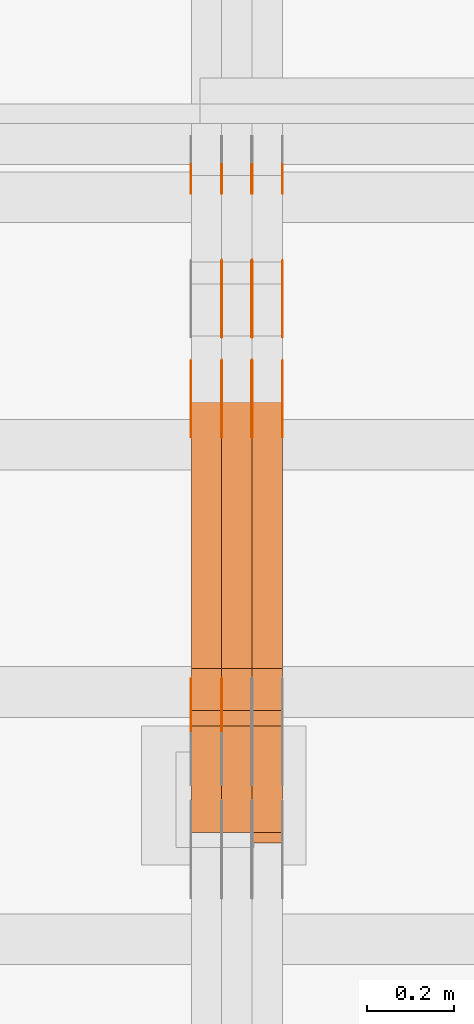
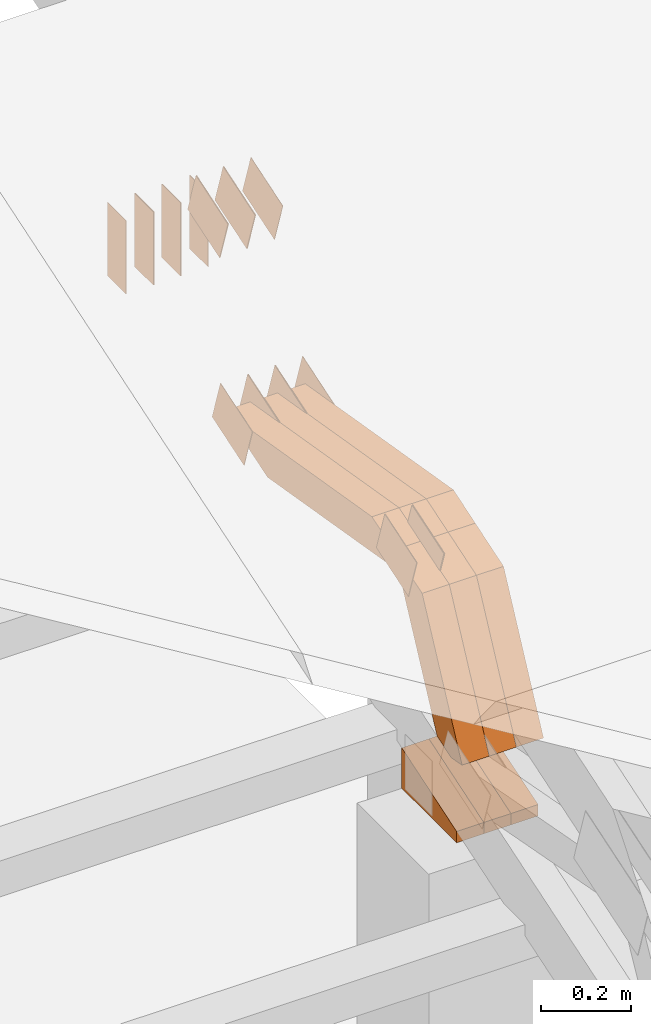
# One storey, part 298 of 385: 29 proxies.
"""IFC2X3 building model written with IfcOpenShell, lengths in millimetres."""

import ifcopenshell
import ifcopenshell.guid

model = None  # the IFC model being written
_history = None  # IfcOwnerHistory: only IFC2X3 demands one
_inside = {}  # id of a spatial element -> (the spatial element, [elements in it])
_under = {}  # id of a project, library or spatial element -> (it, [spatial elements below it])
_declared = {}  # id of a project -> (the project, [libraries it declares])
_typed = {}  # id of a type object -> (the type object, [elements of that type])
_made_of = {}  # id of a material, layer set ... -> (it, [elements and type objects made of it])


def new_model(schema):
    """Start an empty IFC model of exactly this schema.

    Asked for "IFC4X3", IfcOpenShell would pick the latest addendum, in which some entities
    have other attributes; the version numbers below select the first issue.
    IFC2X3 requires an IfcOwnerHistory on every rooted entity: one is made here for all.
    """
    global model, _history
    if schema == "IFC4X3":
        model = ifcopenshell.file(schema_version=(4, 3, 0, 0))
    else:
        model = ifcopenshell.file(schema=schema)
    _inside.clear()
    _under.clear()
    _declared.clear()
    _typed.clear()
    _made_of.clear()
    _history = None
    if model.schema == "IFC2X3":
        org = make("IfcOrganization", Name="unknown")
        user = make(
            "IfcPersonAndOrganization",
            ThePerson=make("IfcPerson", FamilyName="unknown"),
            TheOrganization=org,
        )
        app = make(
            "IfcApplication",
            ApplicationDeveloper=org,
            Version="unknown",
            ApplicationFullName="unknown",
            ApplicationIdentifier="unknown",
        )
        _history = make(
            "IfcOwnerHistory",
            OwningUser=user,
            OwningApplication=app,
            ChangeAction="ADDED",
            CreationDate=0,
        )
    return model


def make(cls, **values):
    """One entity of the class cls with the attributes given. An attribute that is None is left unset."""
    return model.create_entity(
        cls, **{name: value for name, value in values.items() if value is not None}
    )


def entity(cls, *values):
    """Any entity or typed value of the class cls, its attributes in the order of the schema. None: left unset."""
    e = model.create_entity(cls)
    for i, value in enumerate(values):
        if value is not None:
            e[i] = value
    return e


def rooted(cls, **values):
    """An entity with a GlobalId (a new one), such as an element, a storey or a relation."""
    return make(cls, GlobalId=ifcopenshell.guid.new(), OwnerHistory=_history, **values)


def si_unit(unit_type, name, prefix=None):
    """IfcSIUnit, for example si_unit("LENGTHUNIT", "METRE", prefix="MILLI")."""
    return make("IfcSIUnit", UnitType=unit_type, Prefix=prefix, Name=name)


def converted_unit(unit_type, name, factor, base, dimensions=None, offset=None):
    """IfcConversionBasedUnit, such as the inch: factor (a typed value) times the base unit."""
    return make(
        "IfcConversionBasedUnit"
        if offset is None
        else "IfcConversionBasedUnitWithOffset",
        ConversionOffset=offset,
        Dimensions=None
        if dimensions is None
        else entity("IfcDimensionalExponents", *dimensions),
        UnitType=unit_type,
        Name=name,
        ConversionFactor=make(
            "IfcMeasureWithUnit", ValueComponent=factor, UnitComponent=base
        ),
    )


def derived_unit(unit_type, elements):
    """IfcDerivedUnit: a product of units, each with its exponent."""
    return make(
        "IfcDerivedUnit",
        Elements=[
            make("IfcDerivedUnitElement", Unit=unit, Exponent=power)
            for unit, power in elements
        ],
        UnitType=unit_type,
    )


def assignment(units):
    """IfcUnitAssignment: the units of a project."""
    return None if units is None else make("IfcUnitAssignment", Units=units)


def point(xyz):
    """IfcCartesianPoint."""
    return None if xyz is None else make("IfcCartesianPoint", Coordinates=xyz)


def direction(xyz):
    """IfcDirection."""
    return None if xyz is None else make("IfcDirection", DirectionRatios=xyz)


def frame(location, z_axis=None, x_axis=None):
    """IfcAxis2Placement3D, a coordinate frame: its origin and axes. An axis left out is left unset."""
    return make(
        "IfcAxis2Placement3D",
        Location=point(location),
        Axis=direction(z_axis),
        RefDirection=direction(x_axis),
    )


def frame_2d(location, x_axis=None):
    """IfcAxis2Placement2D, a coordinate frame in the plane: its origin and x axis."""
    return make(
        "IfcAxis2Placement2D", Location=point(location), RefDirection=direction(x_axis)
    )


def origin():
    """The frame at (0, 0, 0) with its axes left unset."""
    return frame((0.0, 0.0, 0.0))


def place(relative_to, where):
    """IfcLocalPlacement: puts the frame where relative to a parent placement (None: the world)."""
    return make(
        "IfcLocalPlacement", PlacementRelTo=relative_to, RelativePlacement=where
    )


def context(
    kind, dimensions, precision=None, world=None, true_north=None, identifier=None
):
    """IfcGeometricRepresentationContext, for example the 3D "Model" context."""
    return make(
        "IfcGeometricRepresentationContext",
        ContextIdentifier=identifier,
        ContextType=kind,
        CoordinateSpaceDimension=dimensions,
        Precision=precision,
        WorldCoordinateSystem=world,
        TrueNorth=true_north,
    )


def subcontext(parent, identifier, kind, view, scale=None):
    """IfcGeometricRepresentationSubContext, for example "Body" below "Model"."""
    return make(
        "IfcGeometricRepresentationSubContext",
        ContextIdentifier=identifier,
        ContextType=kind,
        ParentContext=parent,
        TargetScale=scale,
        TargetView=view,
    )


def project(units=None, contexts=None):
    """IfcProject with its units and contexts."""
    return rooted(
        "IfcProject",
        Name="project",
        RepresentationContexts=contexts,
        UnitsInContext=assignment(units),
    )


def spatial(cls, under=None, at=None, **own):
    """A site, building, storey or space (cls), placed at a placement, below another one or the project."""
    s = rooted(cls, ObjectPlacement=at, **own)
    if under is not None:
        _under.setdefault(under.id(), (under, []))[1].append(s)
    return s


def polyline(points):
    """IfcPolyline through the points."""
    return make("IfcPolyline", Points=[point(p) for p in points])


def profile(cls, at=None, kind="AREA", **sizes):
    """A parametric profile (cls). Its sizes go by their IFC names, for example OverallWidth=200.0."""
    return make(cls, ProfileType=kind, Position=at, **sizes)


def rectangle(**sizes):
    """IfcRectangleProfileDef."""
    return profile("IfcRectangleProfileDef", **sizes)


def outline(outer, holes=None, kind="AREA"):
    """IfcArbitraryClosedProfileDef: a profile drawn as a closed curve; with holes, ...WithVoids."""
    if holes is None:
        return make("IfcArbitraryClosedProfileDef", ProfileType=kind, OuterCurve=outer)
    return make(
        "IfcArbitraryProfileDefWithVoids",
        ProfileType=kind,
        OuterCurve=outer,
        InnerCurves=holes,
    )


def extrude(swept, where, along, depth):
    """IfcExtrudedAreaSolid: the profile swept, set in the frame where, extruded along a direction by depth."""
    return make(
        "IfcExtrudedAreaSolid",
        SweptArea=swept,
        Position=where,
        ExtrudedDirection=direction(along),
        Depth=depth,
    )


def shape(context_of_items, identifier, shape_type, items):
    """IfcShapeRepresentation: the items that make up one representation, for example the "Body"."""
    return make(
        "IfcShapeRepresentation",
        ContextOfItems=context_of_items,
        RepresentationIdentifier=identifier,
        RepresentationType=shape_type,
        Items=items,
    )


def source(mapping_origin, context_of_items, identifier, shape_type, items):
    """IfcRepresentationMap: a shape defined once, which mapped items show again and again."""
    return make(
        "IfcRepresentationMap",
        MappingOrigin=mapping_origin,
        MappedRepresentation=shape(context_of_items, identifier, shape_type, items),
    )


def transform(
    local_origin,
    x_axis=None,
    y_axis=None,
    z_axis=None,
    scale=None,
    scale2=None,
    scale3=None,
    uniform=True,
):
    """IfcCartesianTransformationOperator3D, or its non-uniform kind. x_axis, y_axis, z_axis: its Axis1, 2, 3."""
    if uniform:
        return make(
            "IfcCartesianTransformationOperator3D",
            Axis1=direction(x_axis),
            Axis2=direction(y_axis),
            LocalOrigin=point(local_origin),
            Scale=scale,
            Axis3=direction(z_axis),
        )
    return make(
        "IfcCartesianTransformationOperator3DnonUniform",
        Axis1=direction(x_axis),
        Axis2=direction(y_axis),
        LocalOrigin=point(local_origin),
        Scale=scale,
        Axis3=direction(z_axis),
        Scale2=scale2,
        Scale3=scale3,
    )


def mapped(mapping_source, mapping_target):
    """IfcMappedItem: shows the shape of a source again, moved by a transform."""
    return make(
        "IfcMappedItem", MappingSource=mapping_source, MappingTarget=mapping_target
    )


def material(Name=None, Category=None):
    """IfcMaterial."""
    return make("IfcMaterial", Name=Name, Category=Category)


def made_of(thing, what):
    """Note that an element or type object is made of a material, layer set ...; save() writes the relation."""
    if what is not None:
        _made_of.setdefault(what.id(), (what, []))[1].append(thing)
    return thing


def type_object(cls, material=None, **own):
    """A type object (cls), such as IfcWallType, which elements share."""
    return made_of(rooted(cls, **own), material)


def type_shapes(of_type, sources):
    """Give a type object the sources (RepresentationMaps) that its elements show as mapped items."""
    of_type.RepresentationMaps = sources


def element(
    cls,
    number,
    at=None,
    inside=None,
    cuts=None,
    type_object=None,
    material=None,
    context=None,
    identifier="Body",
    shape_type=None,
    held_by="IfcProductDefinitionShape",
    body=None,
    shapes=None,
    **own,
):
    """One element of the class cls, such as IfcWall. Its Tag is "e" and its number.

    at: its placement. inside: the storey or other place that contains it. cuts: it is an
    opening in that element (IfcRelVoidsElement). A single representation is given by context,
    identifier, shape_type and body (its items); several are given by shapes. held_by: the class
    of the entity that holds the representations. save() writes the other relations.
    """
    e = rooted(cls, Tag="e%d" % number, ObjectPlacement=at, **own)
    if body is not None:
        shapes = [shape(context, identifier, shape_type, body)]
    if shapes is not None:
        e.Representation = make(held_by, Representations=shapes)
    if inside is not None:
        _inside.setdefault(inside.id(), (inside, []))[1].append(e)
    if cuts is not None:
        rooted(
            "IfcRelVoidsElement", RelatingBuildingElement=cuts, RelatedOpeningElement=e
        )
    if type_object is not None:
        _typed.setdefault(type_object.id(), (type_object, []))[1].append(e)
    return made_of(e, material)


def aggregate(whole, parts):
    """IfcRelAggregates: a whole, such as a stair, and the parts it consists of."""
    return rooted("IfcRelAggregates", RelatingObject=whole, RelatedObjects=parts)


def save(model, path):
    """Write the relations noted so far, then the file.

    IfcRelAggregates (storeys below a building ...), IfcRelContainedInSpatialStructure (elements
    in a storey), IfcRelDefinesByType, IfcRelAssociatesMaterial and IfcRelDeclares: one each for
    every whole, place, type object, material and project.
    """
    for whole, parts in _under.values():
        aggregate(whole, parts)
    for where, things in _inside.values():
        rooted(
            "IfcRelContainedInSpatialStructure",
            RelatedElements=things,
            RelatingStructure=where,
        )
    for kind, things in _typed.values():
        rooted("IfcRelDefinesByType", RelatedObjects=things, RelatingType=kind)
    for what, things in _made_of.values():
        rooted("IfcRelAssociatesMaterial", RelatedObjects=things, RelatingMaterial=what)
    for by, libraries in _declared.values():
        rooted("IfcRelDeclares", RelatingContext=by, RelatedDefinitions=libraries)
    model.write(path)


model = new_model("IFC2X3")

# Units and contexts
model_context = context("Model", 3, precision=0.01, world=origin(), true_north=direction((6.12303176911189e-17, 1.0)))
body_context = subcontext(model_context, "Body", "Model", "MODEL_VIEW")
ifc_project = project(units=[si_unit("LENGTHUNIT", "METRE", prefix="MILLI"), si_unit("AREAUNIT", "SQUARE_METRE"), si_unit("VOLUMEUNIT", "CUBIC_METRE"), converted_unit("PLANEANGLEUNIT", "DEGREE", entity("IfcRatioMeasure", 0.0174532925199433), si_unit("PLANEANGLEUNIT", "RADIAN"), dimensions=[0, 0, 0, 0, 0, 0, 0]), si_unit("MASSUNIT", "GRAM", prefix="KILO"), derived_unit("MASSDENSITYUNIT", [(si_unit("MASSUNIT", "GRAM", prefix="KILO"), 1), (si_unit("LENGTHUNIT", "METRE"), -3)]), si_unit("TIMEUNIT", "SECOND"), si_unit("FREQUENCYUNIT", "HERTZ"), si_unit("THERMODYNAMICTEMPERATUREUNIT", "DEGREE_CELSIUS"), derived_unit("THERMALTRANSMITTANCEUNIT", [(si_unit("MASSUNIT", "GRAM", prefix="KILO"), 1), (si_unit("THERMODYNAMICTEMPERATUREUNIT", "KELVIN"), -1), (si_unit("TIMEUNIT", "SECOND"), -3)]), derived_unit("VOLUMETRICFLOWRATEUNIT", [(si_unit("LENGTHUNIT", "METRE"), 3), (si_unit("TIMEUNIT", "SECOND"), -1)]), si_unit("ELECTRICCURRENTUNIT", "AMPERE"), si_unit("ELECTRICVOLTAGEUNIT", "VOLT"), si_unit("POWERUNIT", "WATT"), si_unit("FORCEUNIT", "NEWTON", prefix="KILO"), si_unit("ILLUMINANCEUNIT", "LUX"), si_unit("LUMINOUSFLUXUNIT", "LUMEN"), si_unit("LUMINOUSINTENSITYUNIT", "CANDELA"), derived_unit("USERDEFINED", [(si_unit("MASSUNIT", "GRAM", prefix="KILO"), -1), (si_unit("LENGTHUNIT", "METRE"), -2), (si_unit("TIMEUNIT", "SECOND"), 3), (si_unit("LUMINOUSFLUXUNIT", "LUMEN"), 1)]), derived_unit("LINEARVELOCITYUNIT", [(si_unit("LENGTHUNIT", "METRE"), 1), (si_unit("TIMEUNIT", "SECOND"), -1)]), si_unit("PRESSUREUNIT", "PASCAL"), derived_unit("USERDEFINED", [(si_unit("LENGTHUNIT", "METRE"), -2), (si_unit("MASSUNIT", "GRAM", prefix="KILO"), 1), (si_unit("TIMEUNIT", "SECOND"), -2)])], contexts=[model_context])

# Site, building, storey
site_placement = place(None, origin())
site = spatial("IfcSite", under=ifc_project, at=site_placement, CompositionType="ELEMENT")
building_placement = place(site_placement, origin())
building = spatial("IfcBuilding", under=site, at=building_placement, CompositionType="ELEMENT")
storey_placement = place(building_placement, origin())
storey = spatial("IfcBuildingStorey", under=building, at=storey_placement, Name="Default", CompositionType="ELEMENT", Elevation=0.0)

# Proxies
ifc_material_1 = material(Name="IfcSurfaceStyle #553460")
building_element_proxy_type_1 = type_object("IfcBuildingElementProxyType", PredefinedType="NOTDEFINED", material=ifc_material_1)
shared_shape_1 = source(origin(), body_context, "Body", "SweptSolid", [
    extrude(rectangle(XDim=200.0, YDim=84.0, at=frame_2d((0.0, -7.105427357601e-15), x_axis=(1.0, 0.0))), frame((100.0, 42.0, 0.0), z_axis=(0.0, 0.0, 1.0), x_axis=(-1.0, 0.0, 0.0)), (0.0, 0.0, 1.0), 1.3),
])
type_shapes(building_element_proxy_type_1, [shared_shape_1])
proxy_1_placement = place(building_placement, frame((45386.3, 13702.0, 3651.4150390625), z_axis=(-1.0, 0.0, 0.0), x_axis=(0.0, 0.0, -1.0)))
element("IfcBuildingElementProxy", 1, at=proxy_1_placement, inside=storey, type_object=building_element_proxy_type_1, material=ifc_material_1, context=body_context, shape_type="MappedRepresentation", body=[
    mapped(shared_shape_1, transform((0.0, 0.0, 0.0), scale=1.0)),
])
ifc_material_2 = material(Name="IfcSurfaceStyle #553403")
building_element_proxy_type_2 = type_object("IfcBuildingElementProxyType", PredefinedType="NOTDEFINED", material=ifc_material_2)
shared_shape_2 = source(origin(), body_context, "Body", "SweptSolid", [
    extrude(rectangle(XDim=200.0, YDim=84.0, at=frame_2d((0.0, -7.105427357601e-15), x_axis=(1.0, 0.0))), frame((100.0, 42.0, 0.0), z_axis=(0.0, 0.0, 1.0), x_axis=(-1.0, 0.0, 0.0)), (0.0, 0.0, 1.0), 1.3),
])
type_shapes(building_element_proxy_type_2, [shared_shape_2])
proxy_2_placement = place(building_placement, frame((45315.0, 13702.0, 3651.4150390625), z_axis=(-1.0, 0.0, 0.0), x_axis=(0.0, 0.0, -1.0)))
element("IfcBuildingElementProxy", 2, at=proxy_2_placement, inside=storey, type_object=building_element_proxy_type_2, material=ifc_material_2, context=body_context, shape_type="MappedRepresentation", body=[
    mapped(shared_shape_2, transform((0.0, 0.0, 0.0), scale=1.0)),
])
ifc_material_3 = material(Name="IfcSurfaceStyle #553346")
building_element_proxy_type_3 = type_object("IfcBuildingElementProxyType", PredefinedType="NOTDEFINED", material=ifc_material_3)
shared_shape_3 = source(origin(), body_context, "Body", "SweptSolid", [
    extrude(rectangle(XDim=200.0, YDim=84.0, at=frame_2d((0.0, -7.105427357601e-15), x_axis=(1.0, 0.0))), frame((100.0, 42.0, 0.0), z_axis=(0.0, 0.0, 1.0), x_axis=(-1.0, 0.0, 0.0)), (0.0, 0.0, 1.0), 1.3),
])
type_shapes(building_element_proxy_type_3, [shared_shape_3])
proxy_3_placement = place(building_placement, frame((45316.3, 13702.0, 3651.4150390625), z_axis=(-1.0, 0.0, 0.0), x_axis=(0.0, 0.0, -1.0)))
element("IfcBuildingElementProxy", 3, at=proxy_3_placement, inside=storey, type_object=building_element_proxy_type_3, material=ifc_material_3, context=body_context, shape_type="MappedRepresentation", body=[
    mapped(shared_shape_3, transform((0.0, 0.0, 0.0), scale=1.0)),
])
ifc_material_4 = material(Name="IfcSurfaceStyle #553289")
building_element_proxy_type_4 = type_object("IfcBuildingElementProxyType", PredefinedType="NOTDEFINED", material=ifc_material_4)
shared_shape_4 = source(origin(), body_context, "Body", "SweptSolid", [
    extrude(rectangle(XDim=200.0, YDim=84.0, at=frame_2d((0.0, -7.105427357601e-15), x_axis=(1.0, 0.0))), frame((100.0, 42.0, 0.0), z_axis=(0.0, 0.0, 1.0), x_axis=(-1.0, 0.0, 0.0)), (0.0, 0.0, 1.0), 1.29999999999998),
])
type_shapes(building_element_proxy_type_4, [shared_shape_4])
proxy_4_placement = place(building_placement, frame((45245.0, 13702.0, 3651.4150390625), z_axis=(-1.0, 0.0, 0.0), x_axis=(0.0, 0.0, -1.0)))
element("IfcBuildingElementProxy", 4, at=proxy_4_placement, inside=storey, type_object=building_element_proxy_type_4, material=ifc_material_4, context=body_context, shape_type="MappedRepresentation", body=[
    mapped(shared_shape_4, transform((0.0, 0.0, 0.0), scale=1.0)),
])
ifc_material_5 = material(Name="IfcSurfaceStyle #553232")
building_element_proxy_type_5 = type_object("IfcBuildingElementProxyType", PredefinedType="NOTDEFINED", material=ifc_material_5)
shared_shape_5 = source(origin(), body_context, "Body", "SweptSolid", [
    extrude(rectangle(XDim=200.0, YDim=84.0, at=frame_2d((0.0, -7.105427357601e-15), x_axis=(1.0, 0.0))), frame((100.0, 42.0, 0.0), z_axis=(0.0, 0.0, 1.0), x_axis=(-1.0, 0.0, 0.0)), (0.0, 0.0, 1.0), 1.29999999999998),
])
type_shapes(building_element_proxy_type_5, [shared_shape_5])
proxy_5_placement = place(building_placement, frame((45246.3, 13702.0, 3651.4150390625), z_axis=(-1.0, 0.0, 0.0), x_axis=(0.0, 0.0, -1.0)))
element("IfcBuildingElementProxy", 5, at=proxy_5_placement, inside=storey, type_object=building_element_proxy_type_5, material=ifc_material_5, context=body_context, shape_type="MappedRepresentation", body=[
    mapped(shared_shape_5, transform((0.0, 0.0, 0.0), scale=1.0)),
])
ifc_material_6 = material(Name="IfcSurfaceStyle #553175")
building_element_proxy_type_6 = type_object("IfcBuildingElementProxyType", PredefinedType="NOTDEFINED", material=ifc_material_6)
shared_shape_6 = source(origin(), body_context, "Body", "SweptSolid", [
    extrude(rectangle(XDim=200.0, YDim=84.0, at=frame_2d((0.0, -7.105427357601e-15), x_axis=(1.0, 0.0))), frame((100.0, 42.0, 0.0), z_axis=(0.0, 0.0, 1.0), x_axis=(-1.0, 0.0, 0.0)), (0.0, 0.0, 1.0), 1.29999999999999),
])
type_shapes(building_element_proxy_type_6, [shared_shape_6])
proxy_6_placement = place(building_placement, frame((45175.0, 13702.0, 3651.4150390625), z_axis=(-1.0, 0.0, 0.0), x_axis=(0.0, 0.0, -1.0)))
element("IfcBuildingElementProxy", 6, at=proxy_6_placement, inside=storey, type_object=building_element_proxy_type_6, material=ifc_material_6, context=body_context, shape_type="MappedRepresentation", body=[
    mapped(shared_shape_6, transform((0.0, 0.0, 0.0), scale=1.0)),
])
ifc_material_7 = material(Name="IfcSurfaceStyle #553118")
building_element_proxy_type_7 = type_object("IfcBuildingElementProxyType", PredefinedType="NOTDEFINED", material=ifc_material_7)
shared_shape_7 = source(origin(), body_context, "Body", "SweptSolid", [
    extrude(outline(polyline([(-75.0003398116828, -59.9998507501386), (75.0003249421766, -59.9998507501386), (75.0003398116837, 59.9998507501387), (-75.0003249421775, 59.9998507501387), (-75.0003398116828, -59.9998507501386)])), frame((75.0003398116837, 60.0000773549637, 0.0), z_axis=(0.0, 0.0, 1.0), x_axis=(-1.0, 0.0, 0.0)), (0.0, 0.0, 1.0), 1.3),
])
type_shapes(building_element_proxy_type_7, [shared_shape_7])
proxy_7_placement = place(building_placement, frame((45386.3, 13054.73046875, 3417.8388671875), z_axis=(-1.0, 0.0, 0.0), x_axis=(0.0, 0.951056516295124, 0.309016994375039)))
element("IfcBuildingElementProxy", 7, at=proxy_7_placement, inside=storey, type_object=building_element_proxy_type_7, material=ifc_material_7, context=body_context, shape_type="MappedRepresentation", body=[
    mapped(shared_shape_7, transform((0.0, 0.0, 0.0), scale=1.0)),
])
ifc_material_8 = material(Name="IfcSurfaceStyle #553061")
building_element_proxy_type_8 = type_object("IfcBuildingElementProxyType", PredefinedType="NOTDEFINED", material=ifc_material_8)
shared_shape_8 = source(origin(), body_context, "Body", "SweptSolid", [
    extrude(outline(polyline([(-75.0003398116828, -59.9998507501386), (75.0003249421766, -59.9998507501386), (75.0003398116837, 59.9998507501387), (-75.0003249421775, 59.9998507501387), (-75.0003398116828, -59.9998507501386)])), frame((75.0003398116837, 60.0000773549637, 0.0), z_axis=(0.0, 0.0, 1.0), x_axis=(-1.0, 0.0, 0.0)), (0.0, 0.0, 1.0), 1.3),
])
type_shapes(building_element_proxy_type_8, [shared_shape_8])
proxy_8_placement = place(building_placement, frame((45315.0, 13054.73046875, 3417.8388671875), z_axis=(-1.0, 0.0, 0.0), x_axis=(0.0, 0.951056516295124, 0.309016994375039)))
element("IfcBuildingElementProxy", 8, at=proxy_8_placement, inside=storey, type_object=building_element_proxy_type_8, material=ifc_material_8, context=body_context, shape_type="MappedRepresentation", body=[
    mapped(shared_shape_8, transform((0.0, 0.0, 0.0), scale=1.0)),
])
ifc_material_9 = material(Name="IfcSurfaceStyle #553004")
building_element_proxy_type_9 = type_object("IfcBuildingElementProxyType", PredefinedType="NOTDEFINED", material=ifc_material_9)
shared_shape_9 = source(origin(), body_context, "Body", "SweptSolid", [
    extrude(outline(polyline([(-75.0003398116828, -59.9998507501386), (75.0003249421766, -59.9998507501386), (75.0003398116837, 59.9998507501387), (-75.0003249421775, 59.9998507501387), (-75.0003398116828, -59.9998507501386)])), frame((75.0003398116837, 60.0000773549637, 0.0), z_axis=(0.0, 0.0, 1.0), x_axis=(-1.0, 0.0, 0.0)), (0.0, 0.0, 1.0), 1.3),
])
type_shapes(building_element_proxy_type_9, [shared_shape_9])
proxy_9_placement = place(building_placement, frame((45316.3, 13054.73046875, 3417.8388671875), z_axis=(-1.0, 0.0, 0.0), x_axis=(0.0, 0.951056516295124, 0.309016994375039)))
element("IfcBuildingElementProxy", 9, at=proxy_9_placement, inside=storey, type_object=building_element_proxy_type_9, material=ifc_material_9, context=body_context, shape_type="MappedRepresentation", body=[
    mapped(shared_shape_9, transform((0.0, 0.0, 0.0), scale=1.0)),
])
ifc_material_10 = material(Name="IfcSurfaceStyle #552947")
building_element_proxy_type_10 = type_object("IfcBuildingElementProxyType", PredefinedType="NOTDEFINED", material=ifc_material_10)
shared_shape_10 = source(origin(), body_context, "Body", "SweptSolid", [
    extrude(outline(polyline([(-75.0003398116828, -59.9998507501386), (75.0003249421766, -59.9998507501386), (75.0003398116837, 59.9998507501387), (-75.0003249421775, 59.9998507501387), (-75.0003398116828, -59.9998507501386)])), frame((75.0003398116837, 60.0000773549637, 0.0), z_axis=(0.0, 0.0, 1.0), x_axis=(-1.0, 0.0, 0.0)), (0.0, 0.0, 1.0), 1.29999999999999),
])
type_shapes(building_element_proxy_type_10, [shared_shape_10])
proxy_10_placement = place(building_placement, frame((45245.0, 13054.73046875, 3417.8388671875), z_axis=(-1.0, 0.0, 0.0), x_axis=(0.0, 0.951056516295124, 0.309016994375039)))
element("IfcBuildingElementProxy", 10, at=proxy_10_placement, inside=storey, type_object=building_element_proxy_type_10, material=ifc_material_10, context=body_context, shape_type="MappedRepresentation", body=[
    mapped(shared_shape_10, transform((0.0, 0.0, 0.0), scale=1.0)),
])
ifc_material_11 = material(Name="IfcSurfaceStyle #552890")
building_element_proxy_type_11 = type_object("IfcBuildingElementProxyType", PredefinedType="NOTDEFINED", material=ifc_material_11)
shared_shape_11 = source(origin(), body_context, "Body", "SweptSolid", [
    extrude(outline(polyline([(-75.0003398116828, -59.9998507501386), (75.0003249421766, -59.9998507501386), (75.0003398116837, 59.9998507501387), (-75.0003249421775, 59.9998507501387), (-75.0003398116828, -59.9998507501386)])), frame((75.0003398116837, 60.0000773549637, 0.0), z_axis=(0.0, 0.0, 1.0), x_axis=(-1.0, 0.0, 0.0)), (0.0, 0.0, 1.0), 1.29999999999999),
])
type_shapes(building_element_proxy_type_11, [shared_shape_11])
proxy_11_placement = place(building_placement, frame((45246.3, 13054.73046875, 3417.8388671875), z_axis=(-1.0, 0.0, 0.0), x_axis=(0.0, 0.951056516295124, 0.309016994375039)))
element("IfcBuildingElementProxy", 11, at=proxy_11_placement, inside=storey, type_object=building_element_proxy_type_11, material=ifc_material_11, context=body_context, shape_type="MappedRepresentation", body=[
    mapped(shared_shape_11, transform((0.0, 0.0, 0.0), scale=1.0)),
])
ifc_material_12 = material(Name="IfcSurfaceStyle #552833")
building_element_proxy_type_12 = type_object("IfcBuildingElementProxyType", PredefinedType="NOTDEFINED", material=ifc_material_12)
shared_shape_12 = source(origin(), body_context, "Body", "SweptSolid", [
    extrude(outline(polyline([(-75.0003398116828, -59.9998507501386), (75.0003249421766, -59.9998507501386), (75.0003398116837, 59.9998507501387), (-75.0003249421775, 59.9998507501387), (-75.0003398116828, -59.9998507501386)])), frame((75.0003398116837, 60.0000773549637, 0.0), z_axis=(0.0, 0.0, 1.0), x_axis=(-1.0, 0.0, 0.0)), (0.0, 0.0, 1.0), 1.29999999999999),
])
type_shapes(building_element_proxy_type_12, [shared_shape_12])
proxy_12_placement = place(building_placement, frame((45175.0, 13054.73046875, 3417.8388671875), z_axis=(-1.0, 0.0, 0.0), x_axis=(0.0, 0.951056516295124, 0.309016994375039)))
element("IfcBuildingElementProxy", 12, at=proxy_12_placement, inside=storey, type_object=building_element_proxy_type_12, material=ifc_material_12, context=body_context, shape_type="MappedRepresentation", body=[
    mapped(shared_shape_12, transform((0.0, 0.0, 0.0), scale=1.0)),
])
ifc_material_13 = material(Name="IfcSurfaceStyle #545252")
building_element_proxy_type_13 = type_object("IfcBuildingElementProxyType", PredefinedType="NOTDEFINED", material=ifc_material_13)
shared_shape_13 = source(origin(), body_context, "Body", "SweptSolid", [
    extrude(outline(polyline([(-74.999875428623, -60.0000016373506), (74.9998605591059, -60.0000016373506), (74.9998754286239, 60.0000016373506), (-74.9998605591068, 60.0000016373506), (-74.999875428623, -60.0000016373506)])), frame((75.0002691827262, 60.0000190504561, 0.0), z_axis=(0.0, 0.0, 1.0), x_axis=(-1.0, 0.0, 0.0)), (0.0, 0.0, 1.0), 1.3),
])
type_shapes(building_element_proxy_type_13, [shared_shape_13])
proxy_13_placement = place(building_placement, frame((45386.3, 13285.0865109705, 3819.37496637467), z_axis=(-1.0, 0.0, 0.0), x_axis=(0.0, 0.951056516295154, 0.309016994374948)))
element("IfcBuildingElementProxy", 13, at=proxy_13_placement, inside=storey, type_object=building_element_proxy_type_13, material=ifc_material_13, context=body_context, shape_type="MappedRepresentation", body=[
    mapped(shared_shape_13, transform((0.0, 0.0, 0.0), scale=1.0)),
])
ifc_material_14 = material(Name="IfcSurfaceStyle #545195")
building_element_proxy_type_14 = type_object("IfcBuildingElementProxyType", PredefinedType="NOTDEFINED", material=ifc_material_14)
shared_shape_14 = source(origin(), body_context, "Body", "SweptSolid", [
    extrude(outline(polyline([(-74.999875428623, -60.0000016373506), (74.9998605591059, -60.0000016373506), (74.9998754286239, 60.0000016373506), (-74.9998605591068, 60.0000016373506), (-74.999875428623, -60.0000016373506)])), frame((75.0002691827262, 60.0000190504561, 0.0), z_axis=(0.0, 0.0, 1.0), x_axis=(-1.0, 0.0, 0.0)), (0.0, 0.0, 1.0), 1.3),
])
type_shapes(building_element_proxy_type_14, [shared_shape_14])
proxy_14_placement = place(building_placement, frame((45315.0, 13285.0865109705, 3819.37496637467), z_axis=(-1.0, 0.0, 0.0), x_axis=(0.0, 0.951056516295154, 0.309016994374948)))
element("IfcBuildingElementProxy", 14, at=proxy_14_placement, inside=storey, type_object=building_element_proxy_type_14, material=ifc_material_14, context=body_context, shape_type="MappedRepresentation", body=[
    mapped(shared_shape_14, transform((0.0, 0.0, 0.0), scale=1.0)),
])
ifc_material_15 = material(Name="IfcSurfaceStyle #545138")
building_element_proxy_type_15 = type_object("IfcBuildingElementProxyType", PredefinedType="NOTDEFINED", material=ifc_material_15)
shared_shape_15 = source(origin(), body_context, "Body", "SweptSolid", [
    extrude(outline(polyline([(-74.999875428623, -60.0000016373506), (74.9998605591059, -60.0000016373506), (74.9998754286239, 60.0000016373506), (-74.9998605591068, 60.0000016373506), (-74.999875428623, -60.0000016373506)])), frame((75.0002691827262, 60.0000190504561, 0.0), z_axis=(0.0, 0.0, 1.0), x_axis=(-1.0, 0.0, 0.0)), (0.0, 0.0, 1.0), 1.3),
])
type_shapes(building_element_proxy_type_15, [shared_shape_15])
proxy_15_placement = place(building_placement, frame((45316.3, 13285.0865109705, 3819.37496637467), z_axis=(-1.0, 0.0, 0.0), x_axis=(0.0, 0.951056516295154, 0.309016994374948)))
element("IfcBuildingElementProxy", 15, at=proxy_15_placement, inside=storey, type_object=building_element_proxy_type_15, material=ifc_material_15, context=body_context, shape_type="MappedRepresentation", body=[
    mapped(shared_shape_15, transform((0.0, 0.0, 0.0), scale=1.0)),
])
ifc_material_16 = material(Name="IfcSurfaceStyle #545081")
building_element_proxy_type_16 = type_object("IfcBuildingElementProxyType", PredefinedType="NOTDEFINED", material=ifc_material_16)
shared_shape_16 = source(origin(), body_context, "Body", "SweptSolid", [
    extrude(outline(polyline([(-74.999875428623, -60.0000016373506), (74.9998605591059, -60.0000016373506), (74.9998754286239, 60.0000016373506), (-74.9998605591068, 60.0000016373506), (-74.999875428623, -60.0000016373506)])), frame((75.0002691827262, 60.0000190504561, 0.0), z_axis=(0.0, 0.0, 1.0), x_axis=(-1.0, 0.0, 0.0)), (0.0, 0.0, 1.0), 1.29999999999999),
])
type_shapes(building_element_proxy_type_16, [shared_shape_16])
proxy_16_placement = place(building_placement, frame((45245.0, 13285.0865109705, 3819.37496637467), z_axis=(-1.0, 0.0, 0.0), x_axis=(0.0, 0.951056516295154, 0.309016994374948)))
element("IfcBuildingElementProxy", 16, at=proxy_16_placement, inside=storey, type_object=building_element_proxy_type_16, material=ifc_material_16, context=body_context, shape_type="MappedRepresentation", body=[
    mapped(shared_shape_16, transform((0.0, 0.0, 0.0), scale=1.0)),
])
ifc_material_17 = material(Name="IfcSurfaceStyle #545024")
building_element_proxy_type_17 = type_object("IfcBuildingElementProxyType", PredefinedType="NOTDEFINED", material=ifc_material_17)
shared_shape_17 = source(origin(), body_context, "Body", "SweptSolid", [
    extrude(outline(polyline([(-74.999875428623, -60.0000016373506), (74.9998605591059, -60.0000016373506), (74.9998754286239, 60.0000016373506), (-74.9998605591068, 60.0000016373506), (-74.999875428623, -60.0000016373506)])), frame((75.0002691827262, 60.0000190504561, 0.0), z_axis=(0.0, 0.0, 1.0), x_axis=(-1.0, 0.0, 0.0)), (0.0, 0.0, 1.0), 1.29999999999999),
])
type_shapes(building_element_proxy_type_17, [shared_shape_17])
proxy_17_placement = place(building_placement, frame((45246.3, 13285.0865109705, 3819.37496637467), z_axis=(-1.0, 0.0, 0.0), x_axis=(0.0, 0.951056516295154, 0.309016994374948)))
element("IfcBuildingElementProxy", 17, at=proxy_17_placement, inside=storey, type_object=building_element_proxy_type_17, material=ifc_material_17, context=body_context, shape_type="MappedRepresentation", body=[
    mapped(shared_shape_17, transform((0.0, 0.0, 0.0), scale=1.0)),
])
ifc_material_18 = material(Name="IfcSurfaceStyle #543713")
building_element_proxy_type_18 = type_object("IfcBuildingElementProxyType", PredefinedType="NOTDEFINED", material=ifc_material_18)
shared_shape_18 = source(origin(), body_context, "Body", "SweptSolid", [
    extrude(outline(polyline([(-74.9998754286244, -60.0000016373506), (74.9998605591063, -60.0000016373506), (74.9998754286244, 60.0000016373506), (-74.9998605591063, 60.0000016373506), (-74.9998754286244, -60.0000016373506)])), frame((74.9998754286244, 60.0000016373506, 0.0), z_axis=(0.0, 0.0, 1.0), x_axis=(-1.0, 0.0, 0.0)), (0.0, 0.0, 1.0), 1.29999999999999),
])
type_shapes(building_element_proxy_type_18, [shared_shape_18])
proxy_18_placement = place(building_placement, frame((45245.0, 12321.1620861463, 3506.17707344366), z_axis=(-1.0, 0.0, 0.0), x_axis=(0.0, 0.951056516295154, 0.309016994374948)))
element("IfcBuildingElementProxy", 18, at=proxy_18_placement, inside=storey, type_object=building_element_proxy_type_18, material=ifc_material_18, context=body_context, shape_type="MappedRepresentation", body=[
    mapped(shared_shape_18, transform((0.0, 0.0, 0.0), scale=1.0)),
])
ifc_material_19 = material(Name="IfcSurfaceStyle #543656")
building_element_proxy_type_19 = type_object("IfcBuildingElementProxyType", PredefinedType="NOTDEFINED", material=ifc_material_19)
shared_shape_19 = source(origin(), body_context, "Body", "SweptSolid", [
    extrude(outline(polyline([(-74.9998754286244, -60.0000016373506), (74.9998605591063, -60.0000016373506), (74.9998754286244, 60.0000016373506), (-74.9998605591063, 60.0000016373506), (-74.9998754286244, -60.0000016373506)])), frame((74.9998754286244, 60.0000016373506, 0.0), z_axis=(0.0, 0.0, 1.0), x_axis=(-1.0, 0.0, 0.0)), (0.0, 0.0, 1.0), 1.29999999999999),
])
type_shapes(building_element_proxy_type_19, [shared_shape_19])
proxy_19_placement = place(building_placement, frame((45246.3, 12321.1620861463, 3506.17707344366), z_axis=(-1.0, 0.0, 0.0), x_axis=(0.0, 0.951056516295154, 0.309016994374948)))
element("IfcBuildingElementProxy", 19, at=proxy_19_placement, inside=storey, type_object=building_element_proxy_type_19, material=ifc_material_19, context=body_context, shape_type="MappedRepresentation", body=[
    mapped(shared_shape_19, transform((0.0, 0.0, 0.0), scale=1.0)),
])
ifc_material_20 = material(Name="IfcSurfaceStyle #543599")
building_element_proxy_type_20 = type_object("IfcBuildingElementProxyType", PredefinedType="NOTDEFINED", material=ifc_material_20)
shared_shape_20 = source(origin(), body_context, "Body", "SweptSolid", [
    extrude(outline(polyline([(-74.9998754286244, -60.0000016373506), (74.9998605591063, -60.0000016373506), (74.9998754286244, 60.0000016373506), (-74.9998605591063, 60.0000016373506), (-74.9998754286244, -60.0000016373506)])), frame((74.9998754286244, 60.0000016373506, 0.0), z_axis=(0.0, 0.0, 1.0), x_axis=(-1.0, 0.0, 0.0)), (0.0, 0.0, 1.0), 1.29999999999999),
])
type_shapes(building_element_proxy_type_20, [shared_shape_20])
proxy_20_placement = place(building_placement, frame((45175.0, 12321.1620861463, 3506.17707344366), z_axis=(-1.0, 0.0, 0.0), x_axis=(0.0, 0.951056516295154, 0.309016994374948)))
element("IfcBuildingElementProxy", 20, at=proxy_20_placement, inside=storey, type_object=building_element_proxy_type_20, material=ifc_material_20, context=body_context, shape_type="MappedRepresentation", body=[
    mapped(shared_shape_20, transform((0.0, 0.0, 0.0), scale=1.0)),
])
ifc_material_21 = material(Name="IfcSurfaceStyle #535424")
building_element_proxy_type_21 = type_object("IfcBuildingElementProxyType", Name="T1-E1 535422", PredefinedType="NOTDEFINED", material=ifc_material_21)
shared_shape_21 = source(origin(), body_context, "Body", "SweptSolid", [
    extrude(outline(polyline([(-75.1378173828004, -122.500000000005), (35.3350830078246, -122.500000000005), (35.3350830078004, 122.500000000005), (4.46765136717545, 122.500000000005), (-75.1378173828004, -122.500000000005)])), frame((35.3350830078246, 122.500000104877, 0.0), z_axis=(0.0, 0.0, 1.0), x_axis=(-1.0, 0.0, 0.0)), (0.0, 0.0, 1.0), 70.0),
])
type_shapes(building_element_proxy_type_21, [shared_shape_21])
proxy_21_placement = place(building_placement, frame((45385.0, 12145.0, 2849.54565429685), z_axis=(-1.0, 0.0, 0.0), x_axis=(0.0, 0.0, 1.0)))
element("IfcBuildingElementProxy", 21, at=proxy_21_placement, inside=storey, type_object=building_element_proxy_type_21, material=ifc_material_21, Name="T1-E1", context=body_context, shape_type="MappedRepresentation", body=[
    mapped(shared_shape_21, transform((0.0, 0.0, 0.0), scale=1.0)),
])
ifc_material_22 = material(Name="IfcSurfaceStyle #535367")
building_element_proxy_type_22 = type_object("IfcBuildingElementProxyType", Name="T1-E1 535365", PredefinedType="NOTDEFINED", material=ifc_material_22)
shared_shape_22 = source(origin(), body_context, "Body", "SweptSolid", [
    extrude(outline(polyline([(-75.1378173828004, -122.500000000005), (35.3350830078246, -122.500000000005), (35.3350830078004, 122.500000000005), (4.46765136717545, 122.500000000005), (-75.1378173828004, -122.500000000005)])), frame((35.3350830078246, 122.500000104877, 0.0), z_axis=(0.0, 0.0, 1.0), x_axis=(-1.0, 0.0, 0.0)), (0.0, 0.0, 1.0), 70.0),
])
type_shapes(building_element_proxy_type_22, [shared_shape_22])
proxy_22_placement = place(building_placement, frame((45315.0, 12145.0, 2849.54565429685), z_axis=(-1.0, 0.0, 0.0), x_axis=(0.0, 0.0, 1.0)))
element("IfcBuildingElementProxy", 22, at=proxy_22_placement, inside=storey, type_object=building_element_proxy_type_22, material=ifc_material_22, Name="T1-E1", context=body_context, shape_type="MappedRepresentation", body=[
    mapped(shared_shape_22, transform((0.0, 0.0, 0.0), scale=1.0)),
])
ifc_material_23 = material(Name="IfcSurfaceStyle #535310")
building_element_proxy_type_23 = type_object("IfcBuildingElementProxyType", Name="T1-E1 535308", PredefinedType="NOTDEFINED", material=ifc_material_23)
shared_shape_23 = source(origin(), body_context, "Body", "SweptSolid", [
    extrude(outline(polyline([(-75.1378173828004, -122.500000000005), (35.3350830078246, -122.500000000005), (35.3350830078004, 122.500000000005), (4.46765136717545, 122.500000000005), (-75.1378173828004, -122.500000000005)])), frame((35.3350830078246, 122.500000104877, 0.0), z_axis=(0.0, 0.0, 1.0), x_axis=(-1.0, 0.0, 0.0)), (0.0, 0.0, 1.0), 70.0),
])
type_shapes(building_element_proxy_type_23, [shared_shape_23])
proxy_23_placement = place(building_placement, frame((45245.0, 12145.0, 2849.54565429685), z_axis=(-1.0, 0.0, 0.0), x_axis=(0.0, 0.0, 1.0)))
element("IfcBuildingElementProxy", 23, at=proxy_23_placement, inside=storey, type_object=building_element_proxy_type_23, material=ifc_material_23, Name="T1-E1", context=body_context, shape_type="MappedRepresentation", body=[
    mapped(shared_shape_23, transform((0.0, 0.0, 0.0), scale=1.0)),
])
ifc_material_24 = material(Name="IfcSurfaceStyle #533696")
building_element_proxy_type_24 = type_object("IfcBuildingElementProxyType", Name="T1-W7 533694", PredefinedType="NOTDEFINED", material=ifc_material_24)
shared_shape_24 = source(origin(), body_context, "Body", "SweptSolid", [
    extrude(outline(polyline([(-296.174043820986, -47.5000676566704), (297.841254477443, -47.5000676566704), (283.518570346415, -7.10254316533821e-06), (192.674144473719, 47.500071207942), (-477.859925476591, 47.500071207942), (-296.174043820986, -47.5000676566704)])), frame((297.841254477443, 47.5000816097442, 0.0), z_axis=(0.0, 0.0, 1.0), x_axis=(-1.0, 0.0, 0.0)), (0.0, 0.0, 1.0), 70.0),
])
type_shapes(building_element_proxy_type_24, [shared_shape_24])
proxy_24_placement = place(building_placement, frame((45385.0, 12419.2991208897, 3526.2136755972), z_axis=(-1.0, 0.0, 0.0), x_axis=(0.0, 0.985983815111804, -0.166840991178939)))
element("IfcBuildingElementProxy", 24, at=proxy_24_placement, inside=storey, type_object=building_element_proxy_type_24, material=ifc_material_24, Name="T1-W7", context=body_context, shape_type="MappedRepresentation", body=[
    mapped(shared_shape_24, transform((0.0, 0.0, 0.0), scale=1.0)),
])
ifc_material_25 = material(Name="IfcSurfaceStyle #533630")
building_element_proxy_type_25 = type_object("IfcBuildingElementProxyType", Name="T1-W7 533628", PredefinedType="NOTDEFINED", material=ifc_material_25)
shared_shape_25 = source(origin(), body_context, "Body", "SweptSolid", [
    extrude(outline(polyline([(-296.174043820986, -47.5000676566704), (297.841254477443, -47.5000676566704), (283.518570346415, -7.10254316533821e-06), (192.674144473719, 47.500071207942), (-477.859925476591, 47.500071207942), (-296.174043820986, -47.5000676566704)])), frame((297.841254477443, 47.5000816097442, 0.0), z_axis=(0.0, 0.0, 1.0), x_axis=(-1.0, 0.0, 0.0)), (0.0, 0.0, 1.0), 70.0),
])
type_shapes(building_element_proxy_type_25, [shared_shape_25])
proxy_25_placement = place(building_placement, frame((45315.0, 12419.2991208897, 3526.2136755972), z_axis=(-1.0, 0.0, 0.0), x_axis=(0.0, 0.985983815111804, -0.166840991178939)))
element("IfcBuildingElementProxy", 25, at=proxy_25_placement, inside=storey, type_object=building_element_proxy_type_25, material=ifc_material_25, Name="T1-W7", context=body_context, shape_type="MappedRepresentation", body=[
    mapped(shared_shape_25, transform((0.0, 0.0, 0.0), scale=1.0)),
])
ifc_material_26 = material(Name="IfcSurfaceStyle #533564")
building_element_proxy_type_26 = type_object("IfcBuildingElementProxyType", Name="T1-W7 533562", PredefinedType="NOTDEFINED", material=ifc_material_26)
shared_shape_26 = source(origin(), body_context, "Body", "SweptSolid", [
    extrude(outline(polyline([(-296.174043820986, -47.5000676566704), (297.841254477443, -47.5000676566704), (283.518570346415, -7.10254316533821e-06), (192.674144473719, 47.500071207942), (-477.859925476591, 47.500071207942), (-296.174043820986, -47.5000676566704)])), frame((297.841254477443, 47.5000816097442, 0.0), z_axis=(0.0, 0.0, 1.0), x_axis=(-1.0, 0.0, 0.0)), (0.0, 0.0, 1.0), 70.0),
])
type_shapes(building_element_proxy_type_26, [shared_shape_26])
proxy_26_placement = place(building_placement, frame((45245.0, 12419.2991208897, 3526.2136755972), z_axis=(-1.0, 0.0, 0.0), x_axis=(0.0, 0.985983815111804, -0.166840991178939)))
element("IfcBuildingElementProxy", 26, at=proxy_26_placement, inside=storey, type_object=building_element_proxy_type_26, material=ifc_material_26, Name="T1-W7", context=body_context, shape_type="MappedRepresentation", body=[
    mapped(shared_shape_26, transform((0.0, 0.0, 0.0), scale=1.0)),
])
ifc_material_27 = material(Name="IfcSurfaceStyle #533300")
building_element_proxy_type_27 = type_object("IfcBuildingElementProxyType", Name="T1-W36 533298", PredefinedType="NOTDEFINED", material=ifc_material_27)
shared_shape_27 = source(origin(), body_context, "Body", "SweptSolid", [
    extrude(outline(polyline([(-300.714670922549, -47.4998881108849), (134.031527004269, -47.499888110885), (180.52054953879, -0.000136170977331764), (193.89900152221, 47.500563476126), (-207.736407142719, 47.4993489166213), (-300.714670922549, -47.4998881108849)])), frame((193.899145164686, 47.5001861375837, 0.0), z_axis=(0.0, 0.0, 1.0), x_axis=(-1.0, 3.02403492980632e-06, 0.0)), (0.0, 0.0, 1.0), 70.0),
])
type_shapes(building_element_proxy_type_27, [shared_shape_27])
proxy_27_placement = place(building_placement, frame((45385.0, 12120.5935627532, 3076.1128858536), z_axis=(-1.0, 0.0, 0.0), x_axis=(0.0, 0.444384650266842, 0.895836080210669)))
element("IfcBuildingElementProxy", 27, at=proxy_27_placement, inside=storey, type_object=building_element_proxy_type_27, material=ifc_material_27, Name="T1-W36", context=body_context, shape_type="MappedRepresentation", body=[
    mapped(shared_shape_27, transform((0.0, 0.0, 0.0), scale=1.0)),
])
ifc_material_28 = material(Name="IfcSurfaceStyle #533234")
building_element_proxy_type_28 = type_object("IfcBuildingElementProxyType", Name="T1-W36 533232", PredefinedType="NOTDEFINED", material=ifc_material_28)
shared_shape_28 = source(origin(), body_context, "Body", "SweptSolid", [
    extrude(outline(polyline([(-300.714670922549, -47.4998881108849), (134.031527004269, -47.499888110885), (180.52054953879, -0.000136170977331764), (193.89900152221, 47.500563476126), (-207.736407142719, 47.4993489166213), (-300.714670922549, -47.4998881108849)])), frame((193.899145164686, 47.5001861375837, 0.0), z_axis=(0.0, 0.0, 1.0), x_axis=(-1.0, 3.02403492980632e-06, 0.0)), (0.0, 0.0, 1.0), 70.0),
])
type_shapes(building_element_proxy_type_28, [shared_shape_28])
proxy_28_placement = place(building_placement, frame((45315.0, 12120.5935627532, 3076.1128858536), z_axis=(-1.0, 0.0, 0.0), x_axis=(0.0, 0.444384650266842, 0.895836080210669)))
element("IfcBuildingElementProxy", 28, at=proxy_28_placement, inside=storey, type_object=building_element_proxy_type_28, material=ifc_material_28, Name="T1-W36", context=body_context, shape_type="MappedRepresentation", body=[
    mapped(shared_shape_28, transform((0.0, 0.0, 0.0), scale=1.0)),
])
ifc_material_29 = material(Name="IfcSurfaceStyle #533168")
building_element_proxy_type_29 = type_object("IfcBuildingElementProxyType", Name="T1-W36 533166", PredefinedType="NOTDEFINED", material=ifc_material_29)
shared_shape_29 = source(origin(), body_context, "Body", "SweptSolid", [
    extrude(outline(polyline([(-300.714670922549, -47.4998881108849), (134.031527004269, -47.499888110885), (180.52054953879, -0.000136170977331764), (193.89900152221, 47.500563476126), (-207.736407142719, 47.4993489166213), (-300.714670922549, -47.4998881108849)])), frame((193.899145164686, 47.5001861375837, 0.0), z_axis=(0.0, 0.0, 1.0), x_axis=(-1.0, 3.02403492980632e-06, 0.0)), (0.0, 0.0, 1.0), 70.0),
])
type_shapes(building_element_proxy_type_29, [shared_shape_29])
proxy_29_placement = place(building_placement, frame((45245.0, 12120.5935627532, 3076.1128858536), z_axis=(-1.0, 0.0, 0.0), x_axis=(0.0, 0.444384650266842, 0.895836080210669)))
element("IfcBuildingElementProxy", 29, at=proxy_29_placement, inside=storey, type_object=building_element_proxy_type_29, material=ifc_material_29, Name="T1-W36", context=body_context, shape_type="MappedRepresentation", body=[
    mapped(shared_shape_29, transform((0.0, 0.0, 0.0), scale=1.0)),
])

save(model, "model.ifc")
